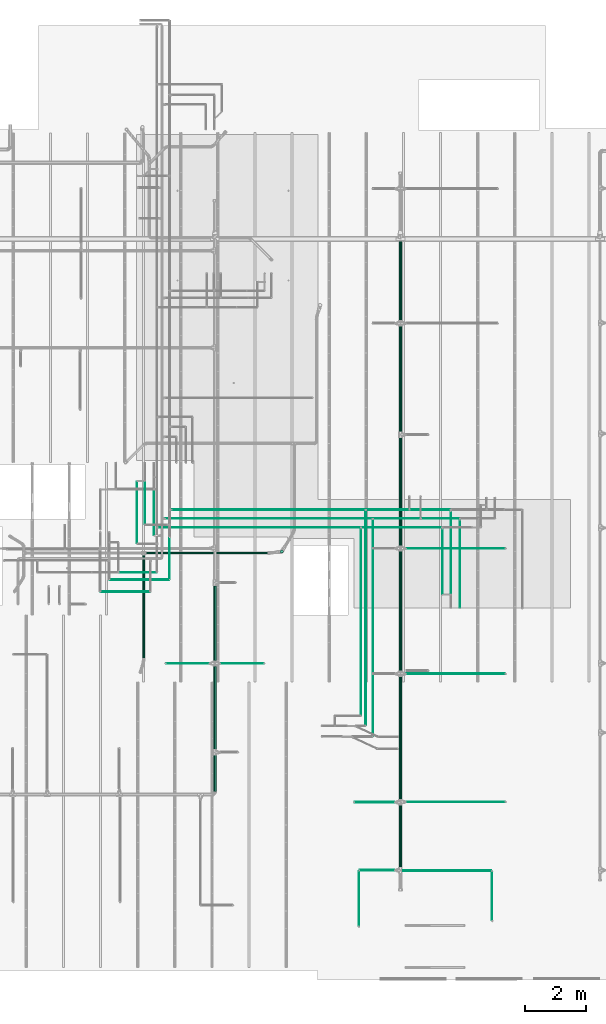
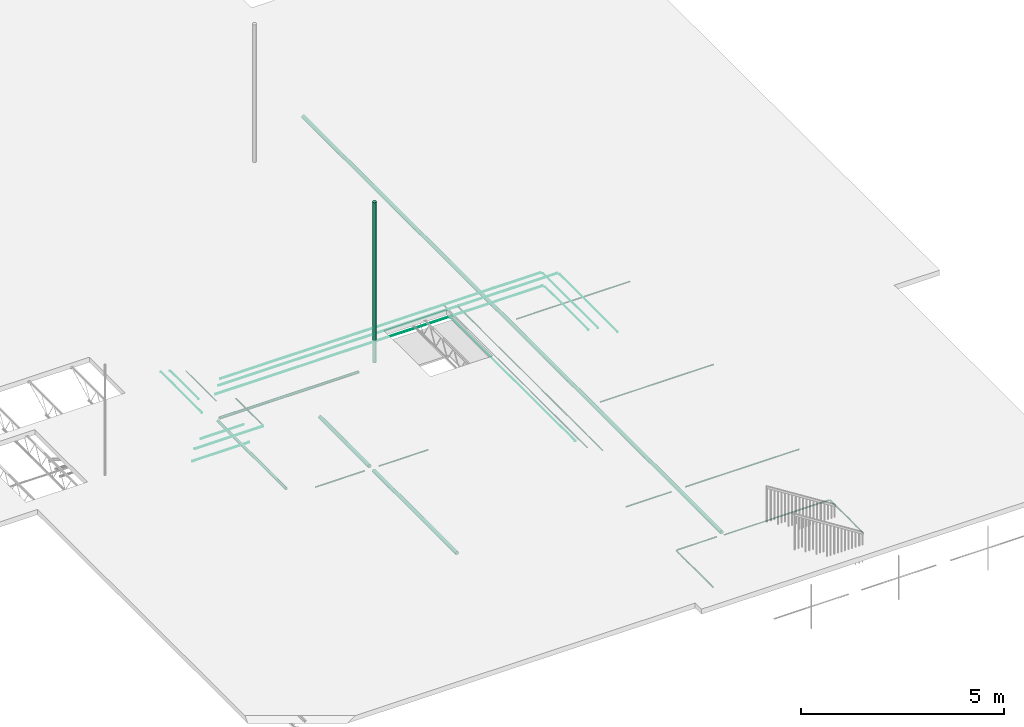
# One storey, part 4 of 173: 37 flow segments.
"""IFC2X3 building model written with IfcOpenShell, lengths in feet."""

from ifc_helpers import new_model, entity, si_unit, converted_unit, derived_unit, direction, frame, origin, origin_2d_with_axis, place, context, subcontext, project, spatial, circle, extrude, source, transform, mapped, type_object, type_shapes, element, save


model = new_model("IFC2X3")

# Units and contexts
model_context = context("Model", 3, precision=0.0001, world=origin(), true_north=direction((6.12303176911189e-17, 1.0)))
body_context = subcontext(model_context, "Body", "Model", "MODEL_VIEW")
ifc_project = project(units=[converted_unit("LENGTHUNIT", "FOOT", entity("IfcRatioMeasure", 0.3048), si_unit("LENGTHUNIT", "METRE"), dimensions=[1, 0, 0, 0, 0, 0, 0]), converted_unit("AREAUNIT", "SQUARE FOOT", entity("IfcRatioMeasure", 0.09290304), si_unit("AREAUNIT", "SQUARE_METRE"), dimensions=[2, 0, 0, 0, 0, 0, 0]), converted_unit("VOLUMEUNIT", "CUBIC FOOT", entity("IfcRatioMeasure", 0.028316846592), si_unit("VOLUMEUNIT", "CUBIC_METRE"), dimensions=[3, 0, 0, 0, 0, 0, 0]), converted_unit("PLANEANGLEUNIT", "DEGREE", entity("IfcRatioMeasure", 0.0174532925199433), si_unit("PLANEANGLEUNIT", "RADIAN"), dimensions=[0, 0, 0, 0, 0, 0, 0]), si_unit("MASSUNIT", "GRAM", prefix="KILO"), derived_unit("MASSDENSITYUNIT", [(si_unit("MASSUNIT", "GRAM", prefix="KILO"), 1), (si_unit("LENGTHUNIT", "METRE"), -3)]), si_unit("TIMEUNIT", "SECOND"), si_unit("FREQUENCYUNIT", "HERTZ"), si_unit("THERMODYNAMICTEMPERATUREUNIT", "DEGREE_CELSIUS"), derived_unit("THERMALTRANSMITTANCEUNIT", [(si_unit("MASSUNIT", "GRAM", prefix="KILO"), 1), (si_unit("THERMODYNAMICTEMPERATUREUNIT", "KELVIN"), -1), (si_unit("TIMEUNIT", "SECOND"), -3)]), derived_unit("VOLUMETRICFLOWRATEUNIT", [(si_unit("LENGTHUNIT", "METRE"), 3), (si_unit("TIMEUNIT", "SECOND"), -1)]), si_unit("ELECTRICCURRENTUNIT", "AMPERE"), si_unit("ELECTRICVOLTAGEUNIT", "VOLT"), si_unit("POWERUNIT", "WATT"), si_unit("FORCEUNIT", "NEWTON"), si_unit("ILLUMINANCEUNIT", "LUX"), si_unit("LUMINOUSFLUXUNIT", "LUMEN"), si_unit("LUMINOUSINTENSITYUNIT", "CANDELA"), derived_unit("USERDEFINED", [(si_unit("MASSUNIT", "GRAM", prefix="KILO"), -1), (si_unit("LENGTHUNIT", "METRE"), -2), (si_unit("TIMEUNIT", "SECOND"), 3), (si_unit("LUMINOUSFLUXUNIT", "LUMEN"), 1)]), derived_unit("LINEARVELOCITYUNIT", [(si_unit("LENGTHUNIT", "METRE"), 1), (si_unit("TIMEUNIT", "SECOND"), -1)]), si_unit("PRESSUREUNIT", "PASCAL"), derived_unit("USERDEFINED", [(si_unit("LENGTHUNIT", "METRE"), -2), (si_unit("MASSUNIT", "GRAM", prefix="KILO"), 1), (si_unit("TIMEUNIT", "SECOND"), -2)])], contexts=[model_context])

# Site, building, storey
site_placement = place(None, origin())
site = spatial("IfcSite", under=ifc_project, at=site_placement, CompositionType="ELEMENT")
building_placement = place(site_placement, origin())
building = spatial("IfcBuilding", under=site, at=building_placement, CompositionType="ELEMENT")
storey_placement = place(building_placement, frame((0.0, 0.0, 8.0)))
storey = spatial("IfcBuildingStorey", under=building, at=storey_placement, Name="REF", CompositionType="ELEMENT", Elevation=8.0)

# Flow segments
pipe_segment_type_1 = type_object("IfcPipeSegmentType", Name="Pipe Types:Standard", PredefinedType="NOTDEFINED")
shared_shape_1 = source(origin(), body_context, "Body", "SweptSolid", [
    extrude(circle(Radius=0.171875, at=origin_2d_with_axis()), frame((10.6090961345433, 8.82471392276889, 11.0944881889764)), (0.0, 0.0, 1.0), 15.8228295193569),
])
type_shapes(pipe_segment_type_1, [shared_shape_1])
flow_segment_1_placement = place(storey_placement, frame((0.0, 0.0, -8.0)))
element("IfcFlowSegment", 1, at=flow_segment_1_placement, inside=storey, type_object=pipe_segment_type_1, Name="Pipe Types:Standard:Standard : Pipe Types:Standard", ObjectType="Standard : Pipe Types:Standard", context=body_context, shape_type="MappedRepresentation", body=[
    mapped(shared_shape_1, transform((0.0, 0.0, 0.0), scale=1.0)),
])
pipe_segment_type_2 = type_object("IfcPipeSegmentType", Name="Pipe Types:Standard", PredefinedType="NOTDEFINED")
shared_shape_2 = source(origin(), body_context, "Body", "SweptSolid", [
    extrude(circle(Radius=0.171875, at=origin_2d_with_axis()), frame((23.3963306532551, -25.1680616330941, 10.4173177083333), z_axis=(0.0, 1.0, 0.0), x_axis=(1.0, 0.0, 0.0)), (0.0, 0.0, 1.0), 67.6712965488149),
])
type_shapes(pipe_segment_type_2, [shared_shape_2])
flow_segment_2_placement = place(storey_placement, frame((0.0, 0.0, -8.0)))
element("IfcFlowSegment", 2, at=flow_segment_2_placement, inside=storey, type_object=pipe_segment_type_2, Name="Pipe Types:Standard:Standard : Pipe Types:Standard", ObjectType="Standard : Pipe Types:Standard", context=body_context, shape_type="MappedRepresentation", body=[
    mapped(shared_shape_2, transform((0.0, 0.0, 0.0), scale=1.0)),
])
pipe_segment_type_3 = type_object("IfcPipeSegmentType", Name="Pipe Types:Standard", PredefinedType="NOTDEFINED")
shared_shape_3 = source(origin(), body_context, "Body", "SweptSolid", [
    extrude(circle(Radius=0.171875, at=origin_2d_with_axis()), frame((3.39633065325514, -2.88605514710684, 10.4173177083333), z_axis=(0.0, 1.0, 0.0), x_axis=(1.0, 0.0, 0.0)), (0.0, 0.0, 1.0), 8.02105084598261),
])
type_shapes(pipe_segment_type_3, [shared_shape_3])
flow_segment_3_placement = place(storey_placement, frame((0.0, 0.0, -8.0)))
element("IfcFlowSegment", 3, at=flow_segment_3_placement, inside=storey, type_object=pipe_segment_type_3, Name="Pipe Types:Standard:Standard : Pipe Types:Standard", ObjectType="Standard : Pipe Types:Standard", context=body_context, shape_type="MappedRepresentation", body=[
    mapped(shared_shape_3, transform((0.0, 0.0, 0.0), scale=1.0)),
])
pipe_segment_type_4 = type_object("IfcPipeSegmentType", Name="Pipe Types:Standard", PredefinedType="NOTDEFINED")
shared_shape_4 = source(origin(), body_context, "Body", "SweptSolid", [
    extrude(circle(Radius=0.046875, at=origin_2d_with_axis()), frame((24.0754645115229, 9.15889829136814, 10.4173177083333), z_axis=(1.0, 0.0, 0.0), x_axis=(0.0, -1.0, 0.0)), (0.0, 0.0, 1.0), 10.5721784776901),
])
type_shapes(pipe_segment_type_4, [shared_shape_4])
flow_segment_4_placement = place(storey_placement, frame((0.0, 0.0, -8.0)))
element("IfcFlowSegment", 4, at=flow_segment_4_placement, inside=storey, type_object=pipe_segment_type_4, Name="Pipe Types:Standard:Standard : Pipe Types:Standard", ObjectType="Standard : Pipe Types:Standard", context=body_context, shape_type="MappedRepresentation", body=[
    mapped(shared_shape_4, transform((0.0, 0.0, 0.0), scale=1.0)),
])
pipe_segment_type_5 = type_object("IfcPipeSegmentType", Name="Pipe Types:Standard", PredefinedType="NOTDEFINED")
shared_shape_5 = source(origin(), body_context, "Body", "SweptSolid", [
    extrude(circle(Radius=0.046875, at=origin_2d_with_axis()), frame((24.0754645115229, -4.34999519270761, 10.4173177083333), z_axis=(1.0, 0.0, 0.0), x_axis=(0.0, -1.0, 0.0)), (0.0, 0.0, 1.0), 10.5721784776901),
])
type_shapes(pipe_segment_type_5, [shared_shape_5])
flow_segment_5_placement = place(storey_placement, frame((0.0, 0.0, -8.0)))
element("IfcFlowSegment", 5, at=flow_segment_5_placement, inside=storey, type_object=pipe_segment_type_5, Name="Pipe Types:Standard:Standard : Pipe Types:Standard", ObjectType="Standard : Pipe Types:Standard", context=body_context, shape_type="MappedRepresentation", body=[
    mapped(shared_shape_5, transform((0.0, 0.0, 0.0), scale=1.0)),
])
pipe_segment_type_6 = type_object("IfcPipeSegmentType", Name="Pipe Types:Standard", PredefinedType="NOTDEFINED")
shared_shape_6 = source(origin(), body_context, "Body", "SweptSolid", [
    extrude(circle(Radius=0.046875, at=origin_2d_with_axis()), frame((24.0754645115229, -18.1550655049833, 10.4173177083333), z_axis=(1.0, 0.0, 0.0), x_axis=(0.0, -1.0, 0.0)), (0.0, 0.0, 1.0), 10.5721784776901),
])
type_shapes(pipe_segment_type_6, [shared_shape_6])
flow_segment_6_placement = place(storey_placement, frame((0.0, 0.0, -8.0)))
element("IfcFlowSegment", 6, at=flow_segment_6_placement, inside=storey, type_object=pipe_segment_type_6, Name="Pipe Types:Standard:Standard : Pipe Types:Standard", ObjectType="Standard : Pipe Types:Standard", context=body_context, shape_type="MappedRepresentation", body=[
    mapped(shared_shape_6, transform((0.0, 0.0, 0.0), scale=1.0)),
])
pipe_segment_type_7 = type_object("IfcPipeSegmentType", Name="Pipe Types:Standard", PredefinedType="NOTDEFINED")
shared_shape_7 = source(origin(), body_context, "Body", "SweptSolid", [
    extrude(circle(Radius=0.046875, at=origin_2d_with_axis()), frame((18.4783516506305, -18.1833285260409, 10.4173177083333), z_axis=(1.0, 0.0, 0.0), x_axis=(0.0, 1.0, 0.0)), (0.0, 0.0, 1.0), 4.23884514435685),
])
type_shapes(pipe_segment_type_7, [shared_shape_7])
flow_segment_7_placement = place(storey_placement, frame((0.0, 0.0, -8.0)))
element("IfcFlowSegment", 7, at=flow_segment_7_placement, inside=storey, type_object=pipe_segment_type_7, Name="Pipe Types:Standard:Standard : Pipe Types:Standard", ObjectType="Standard : Pipe Types:Standard", context=body_context, shape_type="MappedRepresentation", body=[
    mapped(shared_shape_7, transform((0.0, 0.0, 0.0), scale=1.0)),
])
pipe_segment_type_8 = type_object("IfcPipeSegmentType", Name="Pipe Types:Standard", PredefinedType="NOTDEFINED")
shared_shape_8 = source(origin(), body_context, "Body", "SweptSolid", [
    extrude(circle(Radius=0.046875, at=origin_2d_with_axis()), frame((19.0079539027019, -25.5125498220705, 10.4173177083333), z_axis=(1.0, 0.0, 0.0), x_axis=(0.0, 1.0, 0.0)), (0.0, 0.0, 1.0), 3.70924289228548),
])
type_shapes(pipe_segment_type_8, [shared_shape_8])
flow_segment_8_placement = place(storey_placement, frame((0.0, 0.0, -8.0)))
element("IfcFlowSegment", 8, at=flow_segment_8_placement, inside=storey, type_object=pipe_segment_type_8, Name="Pipe Types:Standard:Standard : Pipe Types:Standard", ObjectType="Standard : Pipe Types:Standard", context=body_context, shape_type="MappedRepresentation", body=[
    mapped(shared_shape_8, transform((0.0, 0.0, 0.0), scale=1.0)),
])
pipe_segment_type_9 = type_object("IfcPipeSegmentType", Name="Pipe Types:Standard", PredefinedType="NOTDEFINED")
shared_shape_9 = source(origin(), body_context, "Body", "SweptSolid", [
    extrude(circle(Radius=0.046875, at=origin_2d_with_axis()), frame((18.9259329053265, -31.5138621580285, 10.4173177083333), z_axis=(0.0, 1.0, 0.0), x_axis=(-1.0, 0.0, 0.0)), (0.0, 0.0, 1.0), 5.91929133858272),
])
type_shapes(pipe_segment_type_9, [shared_shape_9])
flow_segment_9_placement = place(storey_placement, frame((0.0, 0.0, -8.0)))
element("IfcFlowSegment", 9, at=flow_segment_9_placement, inside=storey, type_object=pipe_segment_type_9, Name="Pipe Types:Standard:Standard : Pipe Types:Standard", ObjectType="Standard : Pipe Types:Standard", context=body_context, shape_type="MappedRepresentation", body=[
    mapped(shared_shape_9, transform((0.0, 0.0, 0.0), scale=1.0)),
])
pipe_segment_type_10 = type_object("IfcPipeSegmentType", Name="Pipe Types:Standard", PredefinedType="NOTDEFINED")
shared_shape_10 = source(origin(), body_context, "Body", "SweptSolid", [
    extrude(circle(Radius=0.046875, at=origin_2d_with_axis()), frame((23.3963306532551, -25.5731708783073, 10.4173177083333), z_axis=(1.0, 0.0, 0.0), x_axis=(0.0, -1.0, 0.0)), (0.0, 0.0, 1.0), 9.78091458802952),
])
type_shapes(pipe_segment_type_10, [shared_shape_10])
flow_segment_10_placement = place(storey_placement, frame((0.0, 0.0, -8.0)))
element("IfcFlowSegment", 10, at=flow_segment_10_placement, inside=storey, type_object=pipe_segment_type_10, Name="Pipe Types:Standard:Standard : Pipe Types:Standard", ObjectType="Standard : Pipe Types:Standard", context=body_context, shape_type="MappedRepresentation", body=[
    mapped(shared_shape_10, transform((0.0, 0.0, 0.0), scale=1.0)),
])
pipe_segment_type_11 = type_object("IfcPipeSegmentType", Name="Pipe Types:Standard", PredefinedType="NOTDEFINED")
shared_shape_11 = source(origin(), body_context, "Body", "SweptSolid", [
    extrude(circle(Radius=0.046875, at=origin_2d_with_axis()), frame((33.2592662386599, -30.9078165475987, 10.4173177083333), z_axis=(0.0, 1.0, 0.0), x_axis=(-1.0, 0.0, 0.0)), (0.0, 0.0, 1.0), 5.25262467191607),
])
type_shapes(pipe_segment_type_11, [shared_shape_11])
flow_segment_11_placement = place(storey_placement, frame((0.0, 0.0, -8.0)))
element("IfcFlowSegment", 11, at=flow_segment_11_placement, inside=storey, type_object=pipe_segment_type_11, Name="Pipe Types:Standard:Standard : Pipe Types:Standard", ObjectType="Standard : Pipe Types:Standard", context=body_context, shape_type="MappedRepresentation", body=[
    mapped(shared_shape_11, transform((0.0, 0.0, 0.0), scale=1.0)),
])
pipe_segment_type_12 = type_object("IfcPipeSegmentType", Name="Pipe Types:Standard", PredefinedType="NOTDEFINED")
shared_shape_12 = source(origin(), body_context, "Body", "SweptSolid", [
    extrude(circle(Radius=0.046875, at=origin_2d_with_axis()), frame((4.07546451152288, -3.23054333608323, 10.4173177083334), z_axis=(1.0, 0.0, 0.0), x_axis=(0.0, -1.0, 0.0)), (0.0, 0.0, 1.0), 4.57217847769029),
])
type_shapes(pipe_segment_type_12, [shared_shape_12])
flow_segment_12_placement = place(storey_placement, frame((0.0, 0.0, -8.0)))
element("IfcFlowSegment", 12, at=flow_segment_12_placement, inside=storey, type_object=pipe_segment_type_12, Name="Pipe Types:Standard:Standard : Pipe Types:Standard", ObjectType="Standard : Pipe Types:Standard", context=body_context, shape_type="MappedRepresentation", body=[
    mapped(shared_shape_12, transform((0.0, 0.0, 0.0), scale=1.0)),
])
pipe_segment_type_13 = type_object("IfcPipeSegmentType", Name="Pipe Types:Standard", PredefinedType="NOTDEFINED")
shared_shape_13 = source(origin(), body_context, "Body", "SweptSolid", [
    extrude(circle(Radius=0.171875, at=origin_2d_with_axis()), frame((3.39633065325511, -17.021591075797, 10.4173177083333), z_axis=(0.0, 1.0, 0.0), x_axis=(1.0, 0.0, 0.0)), (0.0, 0.0, 1.0), 13.4465595507374),
])
type_shapes(pipe_segment_type_13, [shared_shape_13])
flow_segment_13_placement = place(storey_placement, frame((0.0, 0.0, -8.0)))
element("IfcFlowSegment", 13, at=flow_segment_13_placement, inside=storey, type_object=pipe_segment_type_13, Name="Pipe Types:Standard:Standard : Pipe Types:Standard", ObjectType="Standard : Pipe Types:Standard", context=body_context, shape_type="MappedRepresentation", body=[
    mapped(shared_shape_13, transform((0.0, 0.0, 0.0), scale=1.0)),
])
pipe_segment_type_14 = type_object("IfcPipeSegmentType", Name="Pipe Types:Standard", PredefinedType="NOTDEFINED")
shared_shape_14 = source(origin(), body_context, "Body", "SweptSolid", [
    extrude(circle(Radius=0.046875, at=origin_2d_with_axis()), frame((-1.85498168270289, -3.23054333608321, 10.4173177083334), z_axis=(1.0, 0.0, 0.0), x_axis=(0.0, 1.0, 0.0)), (0.0, 0.0, 1.0), 4.57217847769029),
])
type_shapes(pipe_segment_type_14, [shared_shape_14])
flow_segment_14_placement = place(storey_placement, frame((0.0, 0.0, -8.0)))
element("IfcFlowSegment", 14, at=flow_segment_14_placement, inside=storey, type_object=pipe_segment_type_14, Name="Pipe Types:Standard:Standard : Pipe Types:Standard", ObjectType="Standard : Pipe Types:Standard", context=body_context, shape_type="MappedRepresentation", body=[
    mapped(shared_shape_14, transform((0.0, 0.0, 0.0), scale=1.0)),
])
pipe_segment_type_15 = type_object("IfcPipeSegmentType", Name="Pipe Types:Standard", PredefinedType="NOTDEFINED")
shared_shape_15 = source(origin(), body_context, "Body", "SweptSolid", [
    extrude(circle(Radius=0.0364583333333333, at=origin_2d_with_axis()), frame((-8.89152121620721, 4.50087261103387, 10.75), z_axis=(1.0, 0.0, 0.0), x_axis=(0.0, 1.0, 0.0)), (0.0, 0.0, 1.0), 5.29893229166669),
])
type_shapes(pipe_segment_type_15, [shared_shape_15])
flow_segment_15_placement = place(storey_placement, frame((0.0, 0.0, -8.0)))
element("IfcFlowSegment", 15, at=flow_segment_15_placement, inside=storey, type_object=pipe_segment_type_15, Name="Pipe Types:Standard:Standard : Pipe Types:Standard", ObjectType="Standard : Pipe Types:Standard", context=body_context, shape_type="MappedRepresentation", body=[
    mapped(shared_shape_15, transform((0.0, 0.0, 0.0), scale=1.0)),
])
pipe_segment_type_16 = type_object("IfcPipeSegmentType", Name="Pipe Types:Standard", PredefinedType="NOTDEFINED")
shared_shape_16 = source(origin(), body_context, "Body", "SweptSolid", [
    extrude(circle(Radius=0.0364583333333333, at=origin_2d_with_axis()), frame((20.4210162544578, -11.0645571531881, 11.0), z_axis=(0.0, 1.0, 0.0), x_axis=(-1.0, 0.0, 0.0)), (0.0, 0.0, 1.0), 23.3459884555446),
])
type_shapes(pipe_segment_type_16, [shared_shape_16])
flow_segment_16_placement = place(storey_placement, frame((0.0, 0.0, -8.0)))
element("IfcFlowSegment", 16, at=flow_segment_16_placement, inside=storey, type_object=pipe_segment_type_16, Name="Pipe Types:Standard:Standard : Pipe Types:Standard", ObjectType="Standard : Pipe Types:Standard", context=body_context, shape_type="MappedRepresentation", body=[
    mapped(shared_shape_16, transform((0.0, 0.0, 0.0), scale=1.0)),
])
pipe_segment_type_17 = type_object("IfcPipeSegmentType", Name="Pipe Types:Standard", PredefinedType="NOTDEFINED")
shared_shape_17 = source(origin(), body_context, "Body", "SweptSolid", [
    extrude(circle(Radius=0.0364583333333333, at=origin_2d_with_axis()), frame((-1.91532814929399, 12.3765756593119, 11.0), z_axis=(1.0, 0.0, 0.0), x_axis=(0.0, -1.0, 0.0)), (0.0, 0.0, 1.0), 22.2412000467965),
])
type_shapes(pipe_segment_type_17, [shared_shape_17])
flow_segment_17_placement = place(storey_placement, frame((0.0, 0.0, -8.0)))
element("IfcFlowSegment", 17, at=flow_segment_17_placement, inside=storey, type_object=pipe_segment_type_17, Name="Pipe Types:Standard:Standard : Pipe Types:Standard", ObjectType="Standard : Pipe Types:Standard", context=body_context, shape_type="MappedRepresentation", body=[
    mapped(shared_shape_17, transform((0.0, 0.0, 0.0), scale=1.0)),
])
pipe_segment_type_18 = type_object("IfcPipeSegmentType", Name="Pipe Types:Standard", PredefinedType="NOTDEFINED")
shared_shape_18 = source(origin(), body_context, "Body", "SweptSolid", [
    extrude(circle(Radius=0.0364583333333333, at=origin_2d_with_axis()), frame((20.5161606114132, 12.3765756593119, 11.0), z_axis=(1.0, 0.0, 0.0), x_axis=(0.0, -1.0, 0.0)), (0.0, 0.0, 1.0), 4.96921529862028),
])
type_shapes(pipe_segment_type_18, [shared_shape_18])
flow_segment_18_placement = place(storey_placement, frame((0.0, 0.0, -8.0)))
element("IfcFlowSegment", 18, at=flow_segment_18_placement, inside=storey, type_object=pipe_segment_type_18, Name="Pipe Types:Standard:Standard : Pipe Types:Standard", ObjectType="Standard : Pipe Types:Standard", context=body_context, shape_type="MappedRepresentation", body=[
    mapped(shared_shape_18, transform((0.0, 0.0, 0.0), scale=1.0)),
])
pipe_segment_type_19 = type_object("IfcPipeSegmentType", Name="Pipe Types:Standard", PredefinedType="NOTDEFINED")
shared_shape_19 = source(origin(), body_context, "Body", "SweptSolid", [
    extrude(circle(Radius=0.0364583333333333, at=origin_2d_with_axis()), frame((-3.14564310992399, 10.6028249253688, 11.0), z_axis=(0.0, 1.0, 0.0), x_axis=(1.0, 0.0, 0.0)), (0.0, 0.0, 1.0), 4.83944719156441),
])
type_shapes(pipe_segment_type_19, [shared_shape_19])
flow_segment_19_placement = place(storey_placement, frame((0.0, 0.0, -8.0)))
element("IfcFlowSegment", 19, at=flow_segment_19_placement, inside=storey, type_object=pipe_segment_type_19, Name="Pipe Types:Standard:Standard : Pipe Types:Standard", ObjectType="Standard : Pipe Types:Standard", context=body_context, shape_type="MappedRepresentation", body=[
    mapped(shared_shape_19, transform((0.0, 0.0, 0.0), scale=1.0)),
])
pipe_segment_type_20 = type_object("IfcPipeSegmentType", Name="Pipe Types:Standard", PredefinedType="NOTDEFINED")
shared_shape_20 = source(origin(), body_context, "Body", "SweptSolid", [
    extrude(circle(Radius=0.0364583333333333, at=origin_2d_with_axis()), frame((-1.47897644325732, 5.85726896392487, 10.8333333333333), z_axis=(0.0, 1.0, 0.0), x_axis=(-1.0, 0.0, 0.0)), (0.0, 0.0, 1.0), 4.44047664452099),
])
type_shapes(pipe_segment_type_20, [shared_shape_20])
flow_segment_20_placement = place(storey_placement, frame((0.0, 0.0, -8.0)))
element("IfcFlowSegment", 20, at=flow_segment_20_placement, inside=storey, type_object=pipe_segment_type_20, Name="Pipe Types:Standard:Standard : Pipe Types:Standard", ObjectType="Standard : Pipe Types:Standard", context=body_context, shape_type="MappedRepresentation", body=[
    mapped(shared_shape_20, transform((0.0, 0.0, 0.0), scale=1.0)),
])
pipe_segment_type_21 = type_object("IfcPipeSegmentType", Name="Pipe Types:Standard", PredefinedType="NOTDEFINED")
shared_shape_21 = source(origin(), body_context, "Body", "SweptSolid", [
    extrude(circle(Radius=0.0364583333333333, at=origin_2d_with_axis()), frame((-7.92010925575734, 5.79840177642488, 10.8333333333333), z_axis=(1.0, 0.0, 0.0), x_axis=(0.0, 1.0, 0.0)), (0.0, 0.0, 1.0), 6.38226562500004),
])
type_shapes(pipe_segment_type_21, [shared_shape_21])
flow_segment_21_placement = place(storey_placement, frame((0.0, 0.0, -8.0)))
element("IfcFlowSegment", 21, at=flow_segment_21_placement, inside=storey, type_object=pipe_segment_type_21, Name="Pipe Types:Standard:Standard : Pipe Types:Standard", ObjectType="Standard : Pipe Types:Standard", context=body_context, shape_type="MappedRepresentation", body=[
    mapped(shared_shape_21, transform((0.0, 0.0, 0.0), scale=1.0)),
])
pipe_segment_type_22 = type_object("IfcPipeSegmentType", Name="Pipe Types:Standard", PredefinedType="NOTDEFINED")
shared_shape_22 = source(origin(), body_context, "Body", "SweptSolid", [
    extrude(circle(Radius=0.0364583333333333, at=origin_2d_with_axis()), frame((19.748072698731, 13.3307732913683, 10.8333333333333), z_axis=(1.0, 0.0, 0.0), x_axis=(0.0, -1.0, 0.0)), (0.0, 0.0, 1.0), 4.52806946255725),
])
type_shapes(pipe_segment_type_22, [shared_shape_22])
flow_segment_22_placement = place(storey_placement, frame((0.0, 0.0, -8.0)))
element("IfcFlowSegment", 22, at=flow_segment_22_placement, inside=storey, type_object=pipe_segment_type_22, Name="Pipe Types:Standard:Standard : Pipe Types:Standard", ObjectType="Standard : Pipe Types:Standard", context=body_context, shape_type="MappedRepresentation", body=[
    mapped(shared_shape_22, transform((0.0, 0.0, 0.0), scale=1.0)),
])
pipe_segment_type_23 = type_object("IfcPipeSegmentType", Name="Pipe Types:Standard", PredefinedType="NOTDEFINED")
shared_shape_23 = source(origin(), body_context, "Body", "SweptSolid", [
    extrude(circle(Radius=0.0364583333333333, at=origin_2d_with_axis()), frame((19.6529283417757, -9.90725889319153, 10.8333333333333), z_axis=(0.0, 1.0, 0.0), x_axis=(-1.0, 0.0, 0.0)), (0.0, 0.0, 1.0), 23.1428878276045),
])
type_shapes(pipe_segment_type_23, [shared_shape_23])
flow_segment_23_placement = place(storey_placement, frame((0.0, 0.0, -8.0)))
element("IfcFlowSegment", 23, at=flow_segment_23_placement, inside=storey, type_object=pipe_segment_type_23, Name="Pipe Types:Standard:Standard : Pipe Types:Standard", ObjectType="Standard : Pipe Types:Standard", context=body_context, shape_type="MappedRepresentation", body=[
    mapped(shared_shape_23, transform((0.0, 0.0, 0.0), scale=1.0)),
])
pipe_segment_type_24 = type_object("IfcPipeSegmentType", Name="Pipe Types:Standard", PredefinedType="NOTDEFINED")
shared_shape_24 = source(origin(), body_context, "Body", "SweptSolid", [
    extrude(circle(Radius=0.0364583333333333, at=origin_2d_with_axis()), frame((-1.186981692601, 13.3307732913684, 10.8333333333334), z_axis=(1.0, 0.0, 0.0), x_axis=(0.0, -1.0, 0.0)), (0.0, 0.0, 1.0), 20.7447656774213),
])
type_shapes(pipe_segment_type_24, [shared_shape_24])
flow_segment_24_placement = place(storey_placement, frame((0.0, 0.0, -8.0)))
element("IfcFlowSegment", 24, at=flow_segment_24_placement, inside=storey, type_object=pipe_segment_type_24, Name="Pipe Types:Standard:Standard : Pipe Types:Standard", ObjectType="Standard : Pipe Types:Standard", context=body_context, shape_type="MappedRepresentation", body=[
    mapped(shared_shape_24, transform((0.0, 0.0, 0.0), scale=1.0)),
])
pipe_segment_type_25 = type_object("IfcPipeSegmentType", Name="Pipe Types:Standard", PredefinedType="NOTDEFINED")
shared_shape_25 = source(origin(), body_context, "Body", "SweptSolid", [
    extrude(circle(Radius=0.0364583333333333, at=origin_2d_with_axis()), frame((24.466430875199, 13.3307732913684, 10.8333333333333), z_axis=(1.0, 0.0, 0.0), x_axis=(0.0, -1.0, 0.0)), (0.0, 0.0, 1.0), 4.26097931649443),
])
type_shapes(pipe_segment_type_25, [shared_shape_25])
flow_segment_25_placement = place(storey_placement, frame((0.0, 0.0, -8.0)))
element("IfcFlowSegment", 25, at=flow_segment_25_placement, inside=storey, type_object=pipe_segment_type_25, Name="Pipe Types:Standard:Standard : Pipe Types:Standard", ObjectType="Standard : Pipe Types:Standard", context=body_context, shape_type="MappedRepresentation", body=[
    mapped(shared_shape_25, transform((0.0, 0.0, 0.0), scale=1.0)),
])
pipe_segment_type_26 = type_object("IfcPipeSegmentType", Name="Pipe Types:Standard", PredefinedType="NOTDEFINED")
shared_shape_26 = source(origin(), body_context, "Body", "SweptSolid", [
    extrude(circle(Radius=0.0364583333333333, at=origin_2d_with_axis()), frame((25.6756646239442, 12.3765756593119, 11.0), z_axis=(1.0, 0.0, 0.0), x_axis=(0.0, -1.0, 0.0)), (0.0, 0.0, 1.0), 4.04264346483031),
])
type_shapes(pipe_segment_type_26, [shared_shape_26])
flow_segment_26_placement = place(storey_placement, frame((0.0, 0.0, -8.0)))
element("IfcFlowSegment", 26, at=flow_segment_26_placement, inside=storey, type_object=pipe_segment_type_26, Name="Pipe Types:Standard:Standard : Pipe Types:Standard", ObjectType="Standard : Pipe Types:Standard", context=body_context, shape_type="MappedRepresentation", body=[
    mapped(shared_shape_26, transform((0.0, 0.0, 0.0), scale=1.0)),
])
pipe_segment_type_27 = type_object("IfcPipeSegmentType", Name="Pipe Types:Standard", PredefinedType="NOTDEFINED")
shared_shape_27 = source(origin(), body_context, "Body", "SweptSolid", [
    extrude(circle(Radius=0.0260416666666667, at=origin_2d_with_axis()), frame((29.8134524457299, 2.79577980178508, 11.0), z_axis=(0.0, 1.0, 0.0), x_axis=(-1.0, 0.0, 0.0)), (0.0, 0.0, 1.0), 9.36097958456092),
])
type_shapes(pipe_segment_type_27, [shared_shape_27])
flow_segment_27_placement = place(storey_placement, frame((0.0, 0.0, -8.0)))
element("IfcFlowSegment", 27, at=flow_segment_27_placement, inside=storey, type_object=pipe_segment_type_27, Name="Pipe Types:Standard:Standard : Pipe Types:Standard", ObjectType="Standard : Pipe Types:Standard", context=body_context, shape_type="MappedRepresentation", body=[
    mapped(shared_shape_27, transform((0.0, 0.0, 0.0), scale=1.0)),
])
pipe_segment_type_28 = type_object("IfcPipeSegmentType", Name="Pipe Types:Standard", PredefinedType="NOTDEFINED")
shared_shape_28 = source(origin(), body_context, "Body", "SweptSolid", [
    extrude(circle(Radius=0.0364583333333333, at=origin_2d_with_axis()), frame((-6.88383208630191, 6.58830090493297, 11.0), z_axis=(1.0, 0.0, 0.0), x_axis=(0.0, 1.0, 0.0)), (0.0, 0.0, 1.0), 3.999921910324),
])
type_shapes(pipe_segment_type_28, [shared_shape_28])
flow_segment_28_placement = place(storey_placement, frame((0.0, 0.0, -8.0)))
element("IfcFlowSegment", 28, at=flow_segment_28_placement, inside=storey, type_object=pipe_segment_type_28, Name="Pipe Types:Standard:Standard : Pipe Types:Standard", ObjectType="Standard : Pipe Types:Standard", context=body_context, shape_type="MappedRepresentation", body=[
    mapped(shared_shape_28, transform((0.0, 0.0, 0.0), scale=1.0)),
])
pipe_segment_type_29 = type_object("IfcPipeSegmentType", Name="Pipe Types:Standard", PredefinedType="NOTDEFINED")
shared_shape_29 = source(origin(), body_context, "Body", "SweptSolid", [
    extrude(circle(Radius=0.0260416666666667, at=origin_2d_with_axis()), frame((-4.145643109924, 11.7515182594162, 10.8333333333334), z_axis=(0.0, 1.0, 0.0), x_axis=(1.0, 0.0, 0.0)), (0.0, 0.0, 1.0), 4.57932073109717),
])
type_shapes(pipe_segment_type_29, [shared_shape_29])
flow_segment_29_placement = place(storey_placement, frame((0.0, 0.0, -8.0)))
element("IfcFlowSegment", 29, at=flow_segment_29_placement, inside=storey, type_object=pipe_segment_type_29, Name="Pipe Types:Standard:Standard : Pipe Types:Standard", ObjectType="Standard : Pipe Types:Standard", context=body_context, shape_type="MappedRepresentation", body=[
    mapped(shared_shape_29, transform((0.0, 0.0, 0.0), scale=1.0)),
])
pipe_segment_type_30 = type_object("IfcPipeSegmentType", Name="Pipe Types:Standard", PredefinedType="NOTDEFINED")
shared_shape_30 = source(origin(), body_context, "Body", "SweptSolid", [
    extrude(circle(Radius=0.0260416666666667, at=origin_2d_with_axis()), frame((-4.97897644325733, 9.71119983163869, 11.0), z_axis=(0.0, 1.0, 0.0), x_axis=(-1.0, 0.0, 0.0)), (0.0, 0.0, 1.0), 6.65332031250004),
])
type_shapes(pipe_segment_type_30, [shared_shape_30])
flow_segment_30_placement = place(storey_placement, frame((0.0, 0.0, -8.0)))
element("IfcFlowSegment", 30, at=flow_segment_30_placement, inside=storey, type_object=pipe_segment_type_30, Name="Pipe Types:Standard:Standard : Pipe Types:Standard", ObjectType="Standard : Pipe Types:Standard", context=body_context, shape_type="MappedRepresentation", body=[
    mapped(shared_shape_30, transform((0.0, 0.0, 0.0), scale=1.0)),
])
pipe_segment_type_31 = type_object("IfcPipeSegmentType", Name="Pipe Types:Standard", PredefinedType="NOTDEFINED")
shared_shape_31 = source(origin(), body_context, "Body", "SweptSolid", [
    extrude(circle(Radius=0.0260416666666667, at=origin_2d_with_axis()), frame((28.8225545486488, 4.26167592185028, 10.8333333333334), z_axis=(0.0, 1.0, 0.0), x_axis=(-1.0, 0.0, 0.0)), (0.0, 0.0, 1.0), 8.84928109655222),
])
type_shapes(pipe_segment_type_31, [shared_shape_31])
flow_segment_31_placement = place(storey_placement, frame((0.0, 0.0, -8.0)))
element("IfcFlowSegment", 31, at=flow_segment_31_placement, inside=storey, type_object=pipe_segment_type_31, Name="Pipe Types:Standard:Standard : Pipe Types:Standard", ObjectType="Standard : Pipe Types:Standard", context=body_context, shape_type="MappedRepresentation", body=[
    mapped(shared_shape_31, transform((0.0, 0.0, 0.0), scale=1.0)),
])
pipe_segment_type_32 = type_object("IfcPipeSegmentType", Name="Pipe Types:Standard", PredefinedType="NOTDEFINED")
shared_shape_32 = source(origin(), body_context, "Body", "SweptSolid", [
    extrude(circle(Radius=0.0260416666666667, at=origin_2d_with_axis()), frame((27.9058878819821, 4.22799476822491, 11.0), z_axis=(0.0, 1.0, 0.0), x_axis=(-1.0, 0.0, 0.0)), (0.0, 0.0, 1.0), 6.98378749210029),
])
type_shapes(pipe_segment_type_32, [shared_shape_32])
flow_segment_32_placement = place(storey_placement, frame((0.0, 0.0, -8.0)))
element("IfcFlowSegment", 32, at=flow_segment_32_placement, inside=storey, type_object=pipe_segment_type_32, Name="Pipe Types:Standard:Standard : Pipe Types:Standard", ObjectType="Standard : Pipe Types:Standard", context=body_context, shape_type="MappedRepresentation", body=[
    mapped(shared_shape_32, transform((0.0, 0.0, 0.0), scale=1.0)),
])
pipe_segment_type_33 = type_object("IfcPipeSegmentType", Name="Pipe Types:Standard", PredefinedType="NOTDEFINED")
shared_shape_33 = source(origin(), body_context, "Body", "SweptSolid", [
    extrude(circle(Radius=0.0364583333333333, at=origin_2d_with_axis()), frame((19.248072698731, 11.4315985332911, 11.0), z_axis=(1.0, 0.0, 0.0), x_axis=(0.0, -1.0, 0.0)), (0.0, 0.0, 1.0), 8.56267082629575),
])
type_shapes(pipe_segment_type_33, [shared_shape_33])
flow_segment_33_placement = place(storey_placement, frame((0.0, 0.0, -8.0)))
element("IfcFlowSegment", 33, at=flow_segment_33_placement, inside=storey, type_object=pipe_segment_type_33, Name="Pipe Types:Standard:Standard : Pipe Types:Standard", ObjectType="Standard : Pipe Types:Standard", context=body_context, shape_type="MappedRepresentation", body=[
    mapped(shared_shape_33, transform((0.0, 0.0, 0.0), scale=1.0)),
])
pipe_segment_type_34 = type_object("IfcPipeSegmentType", Name="Pipe Types:Standard", PredefinedType="NOTDEFINED")
shared_shape_34 = source(origin(), body_context, "Body", "SweptSolid", [
    extrude(circle(Radius=0.0260416666666667, at=origin_2d_with_axis()), frame((19.1529283417756, -8.83445290360817, 11.0), z_axis=(0.0, 1.0, 0.0), x_axis=(-1.0, 0.0, 0.0)), (0.0, 0.0, 1.0), 20.0462351639334),
])
type_shapes(pipe_segment_type_34, [shared_shape_34])
flow_segment_34_placement = place(storey_placement, frame((0.0, 0.0, -8.0)))
element("IfcFlowSegment", 34, at=flow_segment_34_placement, inside=storey, type_object=pipe_segment_type_34, Name="Pipe Types:Standard:Standard : Pipe Types:Standard", ObjectType="Standard : Pipe Types:Standard", context=body_context, shape_type="MappedRepresentation", body=[
    mapped(shared_shape_34, transform((0.0, 0.0, 0.0), scale=1.0)),
])
pipe_segment_type_35 = type_object("IfcPipeSegmentType", Name="Pipe Types:Standard", PredefinedType="NOTDEFINED")
shared_shape_35 = source(origin(), body_context, "Body", "SweptSolid", [
    extrude(circle(Radius=0.0364583333333333, at=origin_2d_with_axis()), frame((-2.72989863152243, 11.4315985332911, 11.0), z_axis=(1.0, 0.0, 0.0), x_axis=(0.0, -1.0, 0.0)), (0.0, 0.0, 1.0), 21.7876826163427),
])
type_shapes(pipe_segment_type_35, [shared_shape_35])
flow_segment_35_placement = place(storey_placement, frame((0.0, 0.0, -8.0)))
element("IfcFlowSegment", 35, at=flow_segment_35_placement, inside=storey, type_object=pipe_segment_type_35, Name="Pipe Types:Standard:Standard : Pipe Types:Standard", ObjectType="Standard : Pipe Types:Standard", context=body_context, shape_type="MappedRepresentation", body=[
    mapped(shared_shape_35, transform((0.0, 0.0, 0.0), scale=1.0)),
])
pipe_segment_type_36 = type_object("IfcPipeSegmentType", Name="Pipe Types:Standard", PredefinedType="NOTDEFINED")
shared_shape_36 = source(origin(), body_context, "Body", "SweptSolid", [
    extrude(circle(Radius=0.130208333333333, at=origin_2d_with_axis()), frame((-3.97926027542482, 8.67150827459764, 10.75), z_axis=(1.0, 0.0, 0.0), x_axis=(0.0, -1.0, 0.0)), (0.0, 0.0, 1.0), 13.0337306101473),
])
type_shapes(pipe_segment_type_36, [shared_shape_36])
flow_segment_36_placement = place(storey_placement, frame((0.0, 0.0, -8.0)))
element("IfcFlowSegment", 36, at=flow_segment_36_placement, inside=storey, type_object=pipe_segment_type_36, Name="Pipe Types:Standard:Standard : Pipe Types:Standard", ObjectType="Standard : Pipe Types:Standard", context=body_context, shape_type="MappedRepresentation", body=[
    mapped(shared_shape_36, transform((0.0, 0.0, 0.0), scale=1.0)),
])
pipe_segment_type_37 = type_object("IfcPipeSegmentType", Name="Pipe Types:Standard", PredefinedType="NOTDEFINED")
shared_shape_37 = source(origin(), body_context, "Body", "SweptSolid", [
    extrude(circle(Radius=0.130208333333333, at=origin_2d_with_axis()), frame((-4.26141250639593, -2.66248122671469, 10.75), z_axis=(0.0, 1.0, 0.0), x_axis=(-1.0, 0.0, 0.0)), (0.0, 0.0, 1.0), 11.0518372703412),
])
type_shapes(pipe_segment_type_37, [shared_shape_37])
flow_segment_37_placement = place(storey_placement, frame((0.0, 0.0, -8.0)))
element("IfcFlowSegment", 37, at=flow_segment_37_placement, inside=storey, type_object=pipe_segment_type_37, Name="Pipe Types:Standard:Standard : Pipe Types:Standard", ObjectType="Standard : Pipe Types:Standard", context=body_context, shape_type="MappedRepresentation", body=[
    mapped(shared_shape_37, transform((0.0, 0.0, 0.0), scale=1.0)),
])

save(model, "model.ifc")
